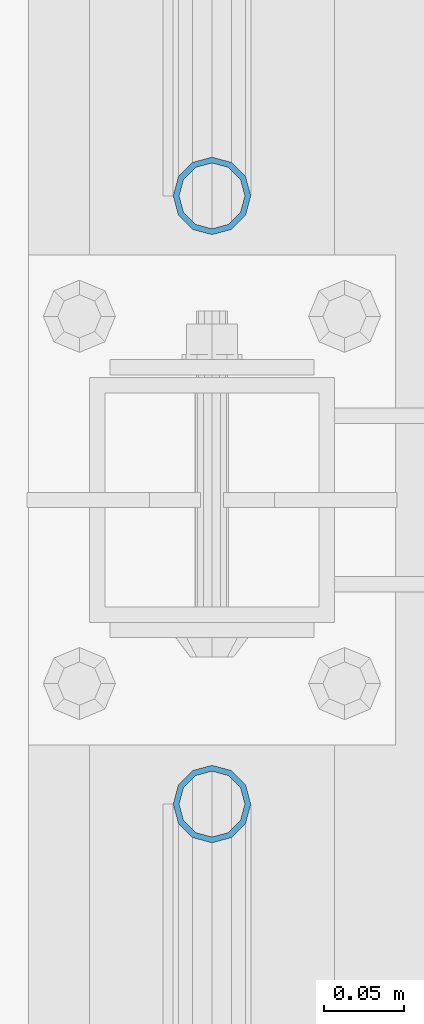
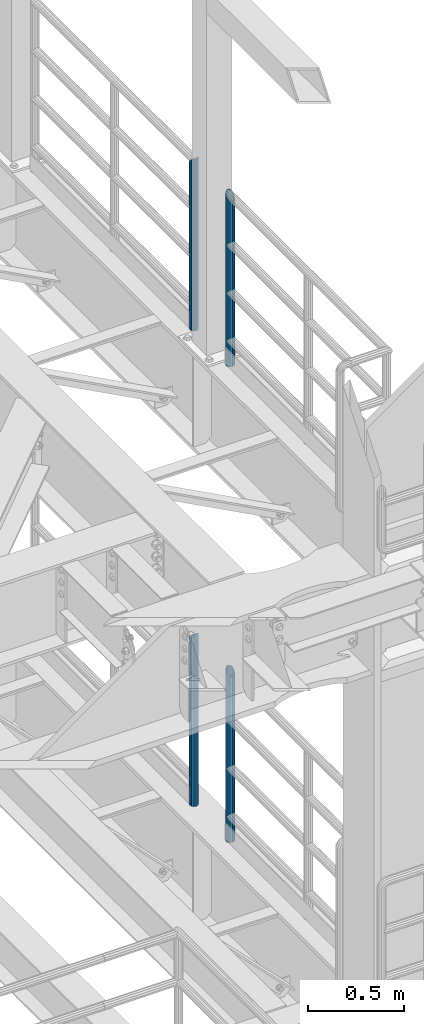
# One storey, part 673 of 1876: 4 columns, 4 elements without a shape of their own.
"""IFC2X3 building model written with IfcOpenShell, lengths in millimetres."""

from ifc_helpers import new_model, si_unit, frame, origin_with_axes, place, context, subcontext, project, spatial, faceted_brep, material, type_object, element, aggregate, save


model = new_model("IFC2X3")

# Units and contexts
model_context = context("Model", 3, precision=1e-05, world=origin_with_axes())
body_context = subcontext(model_context, "Body", "Model", "MODEL_VIEW")
ifc_project = project(units=[si_unit("LENGTHUNIT", "METRE", prefix="MILLI"), si_unit("AREAUNIT", "SQUARE_METRE"), si_unit("VOLUMEUNIT", "CUBIC_METRE"), si_unit("MASSUNIT", "GRAM", prefix="KILO"), si_unit("TIMEUNIT", "SECOND"), si_unit("PLANEANGLEUNIT", "RADIAN"), si_unit("SOLIDANGLEUNIT", "STERADIAN"), si_unit("THERMODYNAMICTEMPERATUREUNIT", "DEGREE_CELSIUS"), si_unit("LUMINOUSINTENSITYUNIT", "LUMEN")], contexts=[model_context])

# Site, building, storey
site_placement = place(None, origin_with_axes())
site = spatial("IfcSite", under=ifc_project, at=site_placement, CompositionType="ELEMENT")
building_placement = place(site_placement, origin_with_axes())
building = spatial("IfcBuilding", under=site, at=building_placement, Name="Undefined", CompositionType="ELEMENT")
storey_placement = place(building_placement, origin_with_axes())
storey = spatial("IfcBuildingStorey", under=building, at=storey_placement, Name="Undefined", CompositionType="ELEMENT", Elevation=0.0)

# Assembly, column
assembly_1_placement = place(storey_placement, origin_with_axes())
assembly_1 = element("IfcElementAssembly", 1, at=assembly_1_placement, inside=storey, Name="RAIL", AssemblyPlace="NOTDEFINED", PredefinedType="RIGID_FRAME")
ifc_material = material()
column_type = type_object("IfcColumnType", Name="PIPE1-1/2SCH40", PredefinedType="NOTDEFINED")
column_1_placement = place(assembly_1_placement, frame((7620.0, -2350.77, 8153.4), z_axis=(0.0, 1.0, 0.0), x_axis=(0.0, 0.0, 1.0)))
column_1 = element("IfcColumn", 2, at=column_1_placement, type_object=column_type, material=ifc_material, Name="POST", ObjectType="PIPE1-1/2SCH40", context=body_context, shape_type="Brep", body=[
    faceted_brep([(0.0, -20.4469999999999, 0.0), (0.0, -17.7076214311803, 10.2235000000001), (1066.1015, -17.7076214311803, 10.2235000000001), (1076.325, -20.4469999999999, 0.0), (0.0, -10.2235000000001, 17.7076214311801), (1058.61737856882, -10.2235000000001, 17.7076214311801), (-1.45519152283669e-11, 0.0, 20.4470000000001), (1055.878, 0.0, 20.4470000000001), (0.0, 10.2235000000001, 17.7076214311801), (1058.61737856882, 10.2235000000001, 17.7076214311801), (0.0, 17.7076214311803, 10.2235000000001), (1066.1015, 17.7076214311803, 10.2235000000001), (0.0, 20.4469999999999, 0.0), (1076.325, 20.4469999999999, 0.0), (0.0, 17.7076214311803, -10.2235000000001), (1086.5485, 17.7076214311803, -10.2235000000001), (0.0, 10.2235000000001, -17.7076214311801), (1094.03262143118, 10.2235000000001, -17.7076214311801), (-1.45519152283669e-11, 0.0, -20.4470000000001), (1096.772, 0.0, -20.4470000000001), (0.0, -10.2235000000001, -17.7076214311801), (1094.03262143118, -10.2235000000001, -17.7076214311801), (0.0, -17.7076214311803, -10.2235000000001), (1086.5485, -17.7076214311803, -10.2235000000001), (0.0, -24.1299999999992, 0.0), (0.0, -20.8971929933184, -12.0649999999996), (1088.39, -20.8971929933184, -12.0649999999996), (1076.325, -24.1300000000001, 0.0), (0.0, -12.0650000000001, -20.8971929933186), (1097.22219299332, -12.0650000000001, -20.8971929933186), (-1.45519152283669e-11, 0.0, -24.130000000001), (1100.455, 0.0, -24.1300000000001), (0.0, 12.0650000000001, -20.8971929933186), (1097.22219299332, 12.0650000000001, -20.8971929933186), (0.0, 20.8971929933184, -12.0649999999996), (1088.39, 20.8971929933184, -12.0649999999996), (0.0, 24.1299999999992, 0.0), (1076.325, 24.1300000000001, 0.0), (0.0, 20.8971929933184, 12.0649999999996), (1064.26, 20.8971929933184, 12.0649999999996), (0.0, 12.0650000000001, 20.8971929933186), (1055.42780700668, 12.0650000000001, 20.8971929933186), (-1.45519152283669e-11, 0.0, 24.130000000001), (1052.195, 0.0, 24.1300000000001), (0.0, -12.0650000000001, 20.8971929933186), (1055.42780700668, -12.0650000000001, 20.8971929933186), (0.0, -20.8971929933184, 12.0649999999996), (1064.26, -20.8971929933184, 12.0649999999996)], [[[0, 1, 2, 3]], [[1, 4, 5, 2]], [[4, 6, 7, 5]], [[6, 8, 9, 7]], [[8, 10, 11, 9]], [[10, 12, 13, 11]], [[12, 14, 15, 13]], [[14, 16, 17, 15]], [[16, 18, 19, 17]], [[18, 20, 21, 19]], [[20, 22, 23, 21]], [[22, 0, 3, 23]], [[24, 25, 26, 27]], [[25, 28, 29, 26]], [[28, 30, 31, 29]], [[30, 32, 33, 31]], [[32, 34, 35, 33]], [[34, 36, 37, 35]], [[36, 38, 39, 37]], [[38, 40, 41, 39]], [[40, 42, 43, 41]], [[42, 44, 45, 43]], [[44, 46, 47, 45]], [[46, 24, 27, 47]], [[29, 31, 33, 35, 37, 39, 41, 43, 45, 47, 27, 26], [5, 7, 9, 11, 13, 15, 17, 19, 21, 23, 3, 2]], [[46, 44, 42, 40, 38, 36, 34, 32, 30, 28, 25, 24], [22, 20, 18, 16, 14, 12, 10, 8, 6, 4, 1, 0]]]),
])
aggregate(assembly_1, [column_1])

assembly_2_placement = place(storey_placement, origin_with_axes())
assembly_2 = element("IfcElementAssembly", 3, at=assembly_2_placement, inside=storey, Name="RAIL", AssemblyPlace="NOTDEFINED", PredefinedType="RIGID_FRAME")
column_2_placement = place(assembly_2_placement, frame((7620.0, -2729.3062, 8153.4), z_axis=(0.0, 1.0, 0.0), x_axis=(0.0, 0.0, 1.0)))
column_2 = element("IfcColumn", 4, at=column_2_placement, type_object=column_type, material=ifc_material, Name="POST", ObjectType="PIPE1-1/2SCH40", context=body_context, shape_type="Brep", body=[
    faceted_brep([(0.0, -20.4469999999999, 0.0), (0.0, -17.7076214311803, 10.2235000000001), (1086.54849999999, -17.7076214311801, 10.2235000000001), (1076.325, -20.4469999999999, 0.0), (0.0, -10.2235000000001, 17.7076214311801), (1094.03262143117, -10.2235000000001, 17.7076214311801), (-1.45519152283669e-11, 0.0, 20.4470000000001), (1096.77199999999, 0.0, 20.4470000000001), (0.0, 10.2235000000001, 17.7076214311801), (1094.03262143117, 10.2235000000001, 17.7076214311801), (0.0, 17.7076214311803, 10.2235000000001), (1086.54849999999, 17.7076214311801, 10.2235000000001), (0.0, 20.4469999999999, 0.0), (1076.325, 20.4469999999999, 0.0), (0.0, 17.7076214311803, -10.2235000000001), (1066.10149999999, 17.7076214311801, -10.2235000000001), (0.0, 10.2235000000001, -17.7076214311801), (1058.61737856881, 10.2235000000001, -17.7076214311801), (-1.45519152283669e-11, 0.0, -20.4470000000001), (1055.87799999999, 0.0, -20.4470000000001), (0.0, -10.2235000000001, -17.7076214311801), (1058.61737856881, -10.2235000000001, -17.7076214311801), (0.0, -17.7076214311803, -10.2235000000001), (1066.10149999999, -17.7076214311801, -10.2235000000001), (0.0, -24.1299999999992, 0.0), (0.0, -20.8971929933184, -12.0649999999996), (1064.25999999999, -20.8971929933186, -12.0649999999996), (1076.325, -24.1300000000001, 0.0), (0.0, -12.0650000000001, -20.8971929933186), (1055.42780700667, -12.0649999999996, -20.8971929933186), (-1.45519152283669e-11, 0.0, -24.130000000001), (1052.19499999999, 0.0, -24.1300000000001), (0.0, 12.0650000000001, -20.8971929933186), (1055.42780700667, 12.0649999999996, -20.8971929933186), (0.0, 20.8971929933184, -12.0649999999996), (1064.25999999999, 20.8971929933186, -12.0649999999996), (0.0, 24.1299999999992, 0.0), (1076.325, 24.1300000000001, 0.0), (0.0, 20.8971929933184, 12.0649999999996), (1088.38999999999, 20.8971929933186, 12.0649999999996), (0.0, 12.0650000000001, 20.8971929933186), (1097.22219299331, 12.0649999999996, 20.8971929933186), (-1.45519152283669e-11, 0.0, 24.130000000001), (1100.45499999999, 0.0, 24.1300000000001), (0.0, -12.0650000000001, 20.8971929933186), (1097.22219299331, -12.0649999999996, 20.8971929933186), (0.0, -20.8971929933184, 12.0649999999996), (1088.38999999999, -20.8971929933186, 12.0649999999996)], [[[0, 1, 2, 3]], [[1, 4, 5, 2]], [[4, 6, 7, 5]], [[6, 8, 9, 7]], [[8, 10, 11, 9]], [[10, 12, 13, 11]], [[12, 14, 15, 13]], [[14, 16, 17, 15]], [[16, 18, 19, 17]], [[18, 20, 21, 19]], [[20, 22, 23, 21]], [[22, 0, 3, 23]], [[24, 25, 26, 27]], [[25, 28, 29, 26]], [[28, 30, 31, 29]], [[30, 32, 33, 31]], [[32, 34, 35, 33]], [[34, 36, 37, 35]], [[36, 38, 39, 37]], [[38, 40, 41, 39]], [[40, 42, 43, 41]], [[42, 44, 45, 43]], [[44, 46, 47, 45]], [[46, 24, 27, 47]], [[29, 31, 33, 35, 37, 39, 41, 43, 45, 47, 27, 26], [5, 7, 9, 11, 13, 15, 17, 19, 21, 23, 3, 2]], [[46, 44, 42, 40, 38, 36, 34, 32, 30, 28, 25, 24], [22, 20, 18, 16, 14, 12, 10, 8, 6, 4, 1, 0]]]),
])
aggregate(assembly_2, [column_2])

assembly_3_placement = place(storey_placement, origin_with_axes())
assembly_3 = element("IfcElementAssembly", 5, at=assembly_3_placement, inside=storey, Name="RAIL", AssemblyPlace="NOTDEFINED", PredefinedType="RIGID_FRAME")
column_3_placement = place(assembly_3_placement, frame((7620.0, -2350.77, 5130.8), z_axis=(0.0, 1.0, 0.0), x_axis=(0.0, 0.0, 1.0)))
column_3 = element("IfcColumn", 6, at=column_3_placement, type_object=column_type, material=ifc_material, Name="POST", ObjectType="PIPE1-1/2SCH40", context=body_context, shape_type="Brep", body=[
    faceted_brep([(0.0, -20.4469999999999, 0.0), (0.0, -17.7076214311803, 10.2235000000001), (1066.1015, -17.7076214311803, 10.2235000000001), (1076.325, -20.4469999999999, 0.0), (0.0, -10.2235000000001, 17.7076214311801), (1058.61737856882, -10.2235000000001, 17.7076214311801), (-1.45519152283669e-11, 0.0, 20.4470000000001), (1055.878, 0.0, 20.4470000000001), (0.0, 10.2235000000001, 17.7076214311801), (1058.61737856882, 10.2235000000001, 17.7076214311801), (0.0, 17.7076214311803, 10.2235000000001), (1066.1015, 17.7076214311803, 10.2235000000001), (0.0, 20.4469999999999, 0.0), (1076.325, 20.4469999999999, 0.0), (0.0, 17.7076214311803, -10.2235000000001), (1086.5485, 17.7076214311803, -10.2235000000001), (0.0, 10.2235000000001, -17.7076214311801), (1094.03262143118, 10.2235000000001, -17.7076214311801), (-1.45519152283669e-11, 0.0, -20.4470000000001), (1096.772, 0.0, -20.4470000000001), (0.0, -10.2235000000001, -17.7076214311801), (1094.03262143118, -10.2235000000001, -17.7076214311801), (0.0, -17.7076214311803, -10.2235000000001), (1086.5485, -17.7076214311803, -10.2235000000001), (0.0, -24.1299999999992, 0.0), (0.0, -20.8971929933184, -12.0649999999996), (1088.39, -20.8971929933184, -12.0649999999996), (1076.325, -24.1300000000001, 0.0), (0.0, -12.0650000000001, -20.8971929933186), (1097.22219299332, -12.0650000000001, -20.8971929933186), (-1.45519152283669e-11, 0.0, -24.130000000001), (1100.455, 0.0, -24.1300000000001), (0.0, 12.0650000000001, -20.8971929933186), (1097.22219299332, 12.0650000000001, -20.8971929933186), (0.0, 20.8971929933184, -12.0649999999996), (1088.39, 20.8971929933184, -12.0649999999996), (0.0, 24.1299999999992, 0.0), (1076.325, 24.1300000000001, 0.0), (0.0, 20.8971929933184, 12.0649999999996), (1064.26, 20.8971929933184, 12.0649999999996), (0.0, 12.0650000000001, 20.8971929933186), (1055.42780700668, 12.0650000000001, 20.8971929933186), (-1.45519152283669e-11, 0.0, 24.130000000001), (1052.195, 0.0, 24.1300000000001), (0.0, -12.0650000000001, 20.8971929933186), (1055.42780700668, -12.0650000000001, 20.8971929933186), (0.0, -20.8971929933184, 12.0649999999996), (1064.26, -20.8971929933184, 12.0649999999996)], [[[0, 1, 2, 3]], [[1, 4, 5, 2]], [[4, 6, 7, 5]], [[6, 8, 9, 7]], [[8, 10, 11, 9]], [[10, 12, 13, 11]], [[12, 14, 15, 13]], [[14, 16, 17, 15]], [[16, 18, 19, 17]], [[18, 20, 21, 19]], [[20, 22, 23, 21]], [[22, 0, 3, 23]], [[24, 25, 26, 27]], [[25, 28, 29, 26]], [[28, 30, 31, 29]], [[30, 32, 33, 31]], [[32, 34, 35, 33]], [[34, 36, 37, 35]], [[36, 38, 39, 37]], [[38, 40, 41, 39]], [[40, 42, 43, 41]], [[42, 44, 45, 43]], [[44, 46, 47, 45]], [[46, 24, 27, 47]], [[29, 31, 33, 35, 37, 39, 41, 43, 45, 47, 27, 26], [5, 7, 9, 11, 13, 15, 17, 19, 21, 23, 3, 2]], [[46, 44, 42, 40, 38, 36, 34, 32, 30, 28, 25, 24], [22, 20, 18, 16, 14, 12, 10, 8, 6, 4, 1, 0]]]),
])
aggregate(assembly_3, [column_3])

assembly_4_placement = place(storey_placement, origin_with_axes())
assembly_4 = element("IfcElementAssembly", 7, at=assembly_4_placement, inside=storey, Name="RAIL", AssemblyPlace="NOTDEFINED", PredefinedType="RIGID_FRAME")
column_4_placement = place(assembly_4_placement, frame((7620.0, -2729.3062, 5130.8), z_axis=(0.0, 1.0, 0.0), x_axis=(0.0, 0.0, 1.0)))
column_4 = element("IfcColumn", 8, at=column_4_placement, type_object=column_type, material=ifc_material, Name="POST", ObjectType="PIPE1-1/2SCH40", context=body_context, shape_type="Brep", body=[
    faceted_brep([(0.0, -20.4469999999999, 0.0), (0.0, -17.7076214311803, 10.2235000000001), (1086.54849999999, -17.7076214311801, 10.2235000000001), (1076.325, -20.4469999999999, 0.0), (0.0, -10.2235000000001, 17.7076214311801), (1094.03262143117, -10.2235000000001, 17.7076214311801), (-1.45519152283669e-11, 0.0, 20.4470000000001), (1096.77199999999, 0.0, 20.4470000000001), (0.0, 10.2235000000001, 17.7076214311801), (1094.03262143117, 10.2235000000001, 17.7076214311801), (0.0, 17.7076214311803, 10.2235000000001), (1086.54849999999, 17.7076214311801, 10.2235000000001), (0.0, 20.4469999999999, 0.0), (1076.325, 20.4469999999999, 0.0), (0.0, 17.7076214311803, -10.2235000000001), (1066.10149999999, 17.7076214311801, -10.2235000000001), (0.0, 10.2235000000001, -17.7076214311801), (1058.61737856881, 10.2235000000001, -17.7076214311801), (-1.45519152283669e-11, 0.0, -20.4470000000001), (1055.87799999999, 0.0, -20.4470000000001), (0.0, -10.2235000000001, -17.7076214311801), (1058.61737856881, -10.2235000000001, -17.7076214311801), (0.0, -17.7076214311803, -10.2235000000001), (1066.10149999999, -17.7076214311801, -10.2235000000001), (0.0, -24.1299999999992, 0.0), (0.0, -20.8971929933184, -12.0649999999996), (1064.25999999999, -20.8971929933186, -12.0649999999996), (1076.325, -24.1300000000001, 0.0), (0.0, -12.0650000000001, -20.8971929933186), (1055.42780700667, -12.0649999999996, -20.8971929933186), (-1.45519152283669e-11, 0.0, -24.130000000001), (1052.19499999999, 0.0, -24.1300000000001), (0.0, 12.0650000000001, -20.8971929933186), (1055.42780700667, 12.0649999999996, -20.8971929933186), (0.0, 20.8971929933184, -12.0649999999996), (1064.25999999999, 20.8971929933186, -12.0649999999996), (0.0, 24.1299999999992, 0.0), (1076.325, 24.1300000000001, 0.0), (0.0, 20.8971929933184, 12.0649999999996), (1088.38999999999, 20.8971929933186, 12.0649999999996), (0.0, 12.0650000000001, 20.8971929933186), (1097.22219299331, 12.0649999999996, 20.8971929933186), (-1.45519152283669e-11, 0.0, 24.130000000001), (1100.45499999999, 0.0, 24.1300000000001), (0.0, -12.0650000000001, 20.8971929933186), (1097.22219299331, -12.0649999999996, 20.8971929933186), (0.0, -20.8971929933184, 12.0649999999996), (1088.38999999999, -20.8971929933186, 12.0649999999996)], [[[0, 1, 2, 3]], [[1, 4, 5, 2]], [[4, 6, 7, 5]], [[6, 8, 9, 7]], [[8, 10, 11, 9]], [[10, 12, 13, 11]], [[12, 14, 15, 13]], [[14, 16, 17, 15]], [[16, 18, 19, 17]], [[18, 20, 21, 19]], [[20, 22, 23, 21]], [[22, 0, 3, 23]], [[24, 25, 26, 27]], [[25, 28, 29, 26]], [[28, 30, 31, 29]], [[30, 32, 33, 31]], [[32, 34, 35, 33]], [[34, 36, 37, 35]], [[36, 38, 39, 37]], [[38, 40, 41, 39]], [[40, 42, 43, 41]], [[42, 44, 45, 43]], [[44, 46, 47, 45]], [[46, 24, 27, 47]], [[29, 31, 33, 35, 37, 39, 41, 43, 45, 47, 27, 26], [5, 7, 9, 11, 13, 15, 17, 19, 21, 23, 3, 2]], [[46, 44, 42, 40, 38, 36, 34, 32, 30, 28, 25, 24], [22, 20, 18, 16, 14, 12, 10, 8, 6, 4, 1, 0]]]),
])
aggregate(assembly_4, [column_4])

save(model, "model.ifc")
